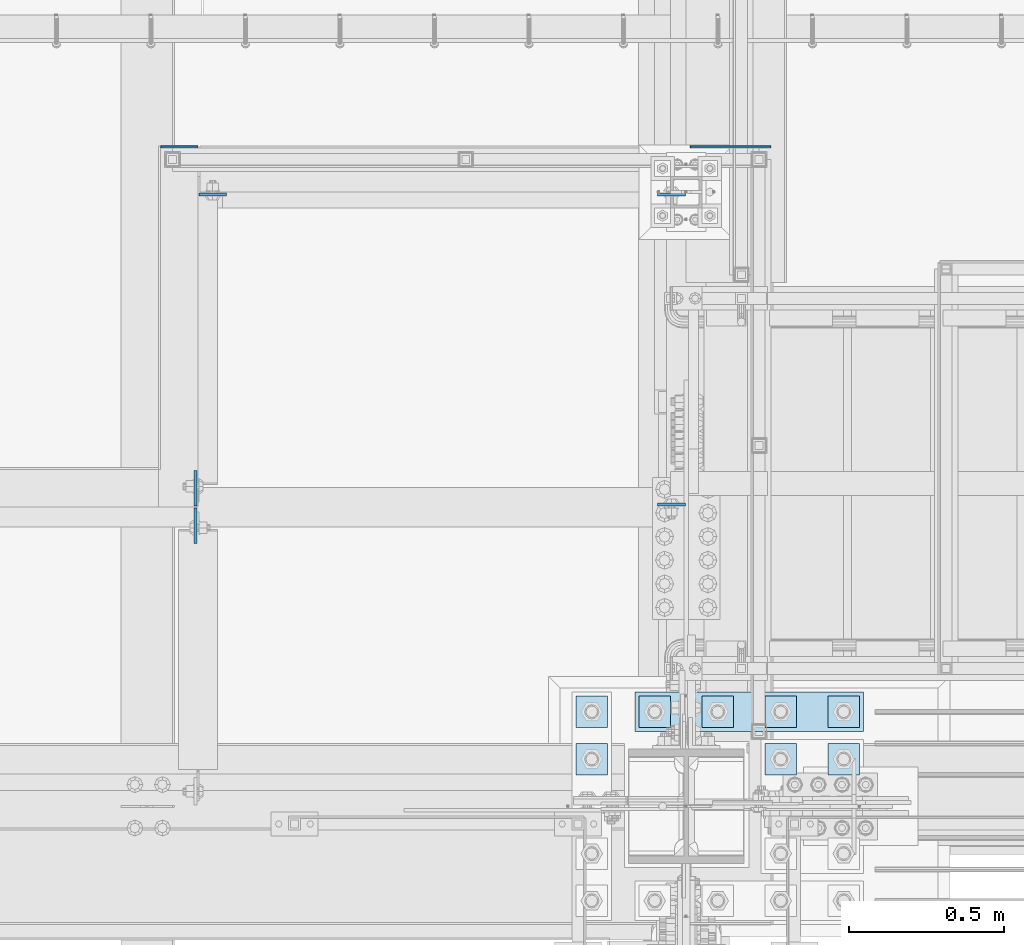
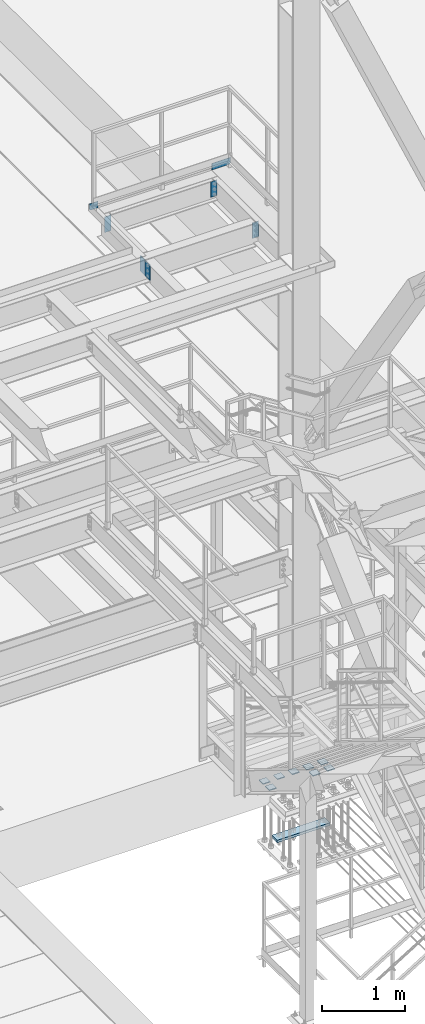
# One storey, part 3153 of 3843: 16 plates, 4 elements without a shape of their own.
"""IFC2X3 building model written with IfcOpenShell, lengths in millimetres."""

from ifc_helpers import new_model, si_unit, frame, origin_with_axes, place, context, subcontext, project, spatial, faceted_brep, material, type_object, element, aggregate, save


model = new_model("IFC2X3")

# Units and contexts
model_context = context("Model", 3, precision=1e-05, world=origin_with_axes())
body_context = subcontext(model_context, "Body", "Model", "MODEL_VIEW")
ifc_project = project(units=[si_unit("LENGTHUNIT", "METRE", prefix="MILLI"), si_unit("AREAUNIT", "SQUARE_METRE"), si_unit("VOLUMEUNIT", "CUBIC_METRE"), si_unit("MASSUNIT", "GRAM", prefix="KILO"), si_unit("TIMEUNIT", "SECOND"), si_unit("PLANEANGLEUNIT", "RADIAN"), si_unit("SOLIDANGLEUNIT", "STERADIAN"), si_unit("THERMODYNAMICTEMPERATUREUNIT", "DEGREE_CELSIUS"), si_unit("LUMINOUSINTENSITYUNIT", "LUMEN")], contexts=[model_context])

# Site, building, storey
site_placement = place(None, origin_with_axes())
site = spatial("IfcSite", under=ifc_project, at=site_placement, CompositionType="ELEMENT")
building_placement = place(site_placement, origin_with_axes())
building = spatial("IfcBuilding", under=site, at=building_placement, Name="Undefined", CompositionType="ELEMENT")
storey_placement = place(building_placement, origin_with_axes())
storey = spatial("IfcBuildingStorey", under=building, at=storey_placement, Name="Undefined", CompositionType="ELEMENT", Elevation=0.0)

# Assembly, plate
assembly_1_placement = place(storey_placement, origin_with_axes())
assembly_1 = element("IfcElementAssembly", 1, at=assembly_1_placement, inside=storey, Name="BEAM", AssemblyPlace="NOTDEFINED", PredefinedType="RIGID_FRAME")
ifc_material = material(Name="STEEL/A572-50")
plate_type_1 = type_object("IfcPlateType", PredefinedType="NOTDEFINED")
plate_1_placement = place(assembly_1_placement, frame((54359.175, 27589.1625, 37426.9), z_axis=(1.0, 0.0, 0.0), x_axis=(0.0, 0.0, -1.0)))
plate_1 = element("IfcPlate", 2, at=plate_1_placement, type_object=plate_type_1, material=ifc_material, Name="PLATE", context=body_context, shape_type="Brep", body=[
    faceted_brep([(0.0, -4.76249999999709, 0.0), (0.0, -4.76249999999709, 88.9000015258789), (0.0, 4.76249999999709, 88.9000015258789), (0.0, 4.76249999999709, 0.0), (228.600006102781, -4.7625000004191, 88.9000015257589), (228.600006102781, 4.76249999954598, 88.9000015257443), (228.600006103079, -4.7625000004482, 7.27595761418343e-12), (228.600006103079, 4.76249999954598, -7.27595761418343e-12)], [[[0, 1, 2, 3]], [[1, 4, 5, 2]], [[4, 6, 7, 5]], [[6, 0, 3, 7]], [[5, 7, 3, 2]], [[6, 4, 1, 0]]]),
])

# Assembly, plates
assembly_2_placement = place(storey_placement, origin_with_axes())
assembly_2 = element("IfcElementAssembly", 3, at=assembly_2_placement, inside=storey, Name="BEAM", AssemblyPlace="NOTDEFINED", PredefinedType="RIGID_FRAME")
plate_2_placement = place(assembly_2_placement, frame((55927.625, 27589.1625, 37426.9), z_axis=(-1.0, 0.0, 0.0), x_axis=(0.0, 0.0, -1.0)))
plate_2 = element("IfcPlate", 4, at=plate_2_placement, type_object=plate_type_1, material=ifc_material, Name="PLATE", context=body_context, shape_type="Brep", body=[
    faceted_brep([(0.0, -4.76249999999709, 0.0), (0.0, -4.76249999999709, 88.9000015258789), (0.0, 4.76249999999709, 88.9000015258789), (0.0, 4.76249999999709, 0.0), (228.600006102781, -4.7625000004191, 88.9000015257589), (228.600006102781, 4.76249999954598, 88.9000015257443), (228.600006103079, -4.7625000004482, 7.27595761418343e-12), (228.600006103079, 4.76249999954598, -7.27595761418343e-12)], [[[0, 1, 2, 3]], [[1, 4, 5, 2]], [[4, 6, 7, 5]], [[6, 0, 3, 7]], [[5, 7, 3, 2]], [[6, 4, 1, 0]]]),
])
plate_3_placement = place(assembly_2_placement, frame((55927.625, 26589.0375, 37426.9), z_axis=(-1.0, 0.0, 0.0), x_axis=(0.0, 0.0, -1.0)))
plate_3 = element("IfcPlate", 5, at=plate_3_placement, type_object=plate_type_1, material=ifc_material, Name="PLATE", context=body_context, shape_type="Brep", body=[
    faceted_brep([(0.0, -4.76249999999709, 0.0), (0.0, -4.76249999999709, 88.9000015258789), (0.0, 4.76249999999709, 88.9000015258789), (0.0, 4.76249999999709, 0.0), (228.600006102781, -4.7625000004191, 88.9000015257589), (228.600006102781, 4.76249999954598, 88.9000015257443), (228.600006103079, -4.7625000004482, 7.27595761418343e-12), (228.600006103079, 4.76249999954598, -7.27595761418343e-12)], [[[0, 1, 2, 3]], [[1, 4, 5, 2]], [[4, 6, 7, 5]], [[6, 0, 3, 7]], [[5, 7, 3, 2]], [[6, 4, 1, 0]]]),
])

# Plate
plate_type_2 = type_object("IfcPlateType", PredefinedType="NOTDEFINED")
plate_4_placement = place(assembly_1_placement, frame((54235.35, 27743.15, 37471.35), z_axis=(0.0, 0.0, 1.0), x_axis=(1.0, 0.0, 0.0)))
plate_4 = element("IfcPlate", 6, at=plate_4_placement, type_object=plate_type_2, material=ifc_material, Name="PLATE", context=body_context, shape_type="Brep", body=[
    faceted_brep([(4.36557456851006e-11, -3.17499999998836, 19.0499992370969), (0.0, -3.17499999999927, 95.25), (-2.44140610448085e-05, 3.17500000000291, 95.2499999999927), (1.45519152283669e-11, 3.17499999998836, 19.0499992370824), (120.649996948239, -3.17499999999927, 95.25), (120.649996948239, 3.17499999999927, 95.25), (120.650001525879, -3.17499999999927, 0.0), (120.650001525879, 3.17499999999927, 0.0), (19.0499992370023, -3.17500000005384, 0.0), (19.0499992369587, 3.17499999992287, -1.45519152283669e-11)], [[[0, 1, 2, 3]], [[1, 4, 5, 2]], [[4, 6, 7, 5]], [[6, 8, 9, 7]], [[8, 0, 3, 9]], [[5, 7, 9, 3, 2]], [[8, 6, 4, 1, 0]]]),
])

aggregate(assembly_1, [plate_4, plate_1])

plate_5_placement = place(assembly_2_placement, frame((55943.5, 27743.1497862042, 37471.35), z_axis=(0.0, 0.0, 1.0), x_axis=(1.0, 0.0, 0.0)))
plate_5 = element("IfcPlate", 7, at=plate_5_placement, type_object=plate_type_2, material=ifc_material, Name="PLATE", context=body_context, shape_type="Brep", body=[
    faceted_brep([(0.0, -3.17499999999927, 0.0), (0.0, -3.17499999999927, 95.25), (-2.44140610448085e-05, 3.17500000000291, 95.2499999999927), (0.0, 3.17499999999927, 0.0), (260.350006103516, -3.17499999999927, 95.25), (260.350006103516, 3.17499999999927, 95.25), (260.350006103516, -3.17499999999927, 19.0499992370605), (260.350006103516, 3.17499999999927, 19.0499992370605), (241.300006866455, -3.17499999999927, 0.0), (241.300006866455, 3.17499999999927, 0.0)], [[[0, 1, 2, 3]], [[1, 4, 5, 2]], [[4, 6, 7, 5]], [[6, 8, 9, 7]], [[8, 0, 3, 9]], [[5, 7, 9, 3, 2]], [[8, 6, 4, 1, 0]]]),
])

aggregate(assembly_2, [plate_5, plate_2, plate_3])

# Assembly, plates
assembly_3_placement = place(storey_placement, origin_with_axes())
assembly_3 = element("IfcElementAssembly", 8, at=assembly_3_placement, inside=storey, Name="BEAM", AssemblyPlace="NOTDEFINED", PredefinedType="RIGID_FRAME")
plate_type_3 = type_object("IfcPlateType", PredefinedType="NOTDEFINED")
plate_6_placement = place(assembly_3_placement, frame((54348.0625, 26584.275, 37404.675), z_axis=(0.0, 1.0, 0.0), x_axis=(0.0, 0.0, -1.0)))
plate_6 = element("IfcPlate", 9, at=plate_6_placement, type_object=plate_type_3, material=ifc_material, Name="PLATE", context=body_context, shape_type="Brep", body=[
    faceted_brep([(0.0, -4.76249999999709, 0.0), (0.0, -4.76249999999709, 114.300003051758), (0.0, 4.76249999999709, 114.300003051758), (0.0, 4.76249999999709, 0.0), (228.600006103516, -4.76249999999709, 114.300003051758), (228.600006103516, 4.76249999999709, 114.300003051758), (228.600006103079, -4.7625000004482, 7.27595761418343e-12), (228.600006103079, 4.76249999954598, -7.27595761418343e-12)], [[[0, 1, 2, 3]], [[1, 4, 5, 2]], [[4, 6, 7, 5]], [[6, 0, 3, 7]], [[5, 7, 3, 2]], [[6, 4, 1, 0]]]),
])
plate_7_placement = place(assembly_3_placement, frame((54348.0625, 26577.925, 37404.675), z_axis=(0.0, -1.0, 0.0), x_axis=(0.0, 0.0, -1.0)))
plate_7 = element("IfcPlate", 10, at=plate_7_placement, type_object=plate_type_3, material=ifc_material, Name="PLATE", context=body_context, shape_type="Brep", body=[
    faceted_brep([(0.0, -4.76249999999709, 0.0), (0.0, -4.76249999999709, 114.300003051758), (0.0, 4.76249999999709, 114.300003051758), (0.0, 4.76249999999709, 0.0), (228.600006103516, -4.76249999999709, 114.300003051758), (228.600006103516, 4.76249999999709, 114.300003051758), (228.600006103079, -4.7625000004482, 7.27595761418343e-12), (228.600006103079, 4.76249999954598, -7.27595761418343e-12)], [[[0, 1, 2, 3]], [[1, 4, 5, 2]], [[4, 6, 7, 5]], [[6, 0, 3, 7]], [[5, 7, 3, 2]], [[6, 4, 1, 0]]]),
])
aggregate(assembly_3, [plate_6, plate_7])

assembly_4_placement = place(storey_placement, origin_with_axes())
assembly_4 = element("IfcElementAssembly", 11, at=assembly_4_placement, inside=storey, Name="TEMPLATE", AssemblyPlace="NOTDEFINED", PredefinedType="RIGID_FRAME")
plate_type_4 = type_object("IfcPlateType", PredefinedType="NOTDEFINED")
plate_8_placement = place(assembly_4_placement, frame((55676.8, 25819.1, 29686.25), z_axis=(-1.0, 0.0, 0.0), x_axis=(0.0, -1.0, 0.0)))
plate_8 = element("IfcPlate", 12, at=plate_8_placement, type_object=plate_type_4, material=ifc_material, Name="Washer Plate", context=body_context, shape_type="Brep", body=[
    faceted_brep([(0.0, -6.3499999046162, 0.0), (-1.67347025126219e-10, -6.35000000000582, 101.600000000151), (-1.67347025126219e-10, 6.35000000000582, 101.600000000151), (7.27595761418343e-12, 6.3499999046162, 0.0), (101.599998474121, -6.34999999999854, 101.599998474121), (101.599998474121, 6.34999999999854, 101.599998474121), (101.6, -6.34999999999854, 0.0), (101.6, 6.34999999999854, 0.0)], [[[0, 1, 2, 3]], [[1, 4, 5, 2]], [[4, 6, 7, 5]], [[6, 0, 3, 7]], [[5, 7, 3, 2]], [[6, 4, 1, 0]]]),
])
plate_9_placement = place(assembly_4_placement, frame((56286.4, 25819.1, 29686.25), z_axis=(-1.0, 0.0, 0.0), x_axis=(0.0, -1.0, 0.0)))
plate_9 = element("IfcPlate", 13, at=plate_9_placement, type_object=plate_type_4, material=ifc_material, Name="Washer Plate", context=body_context, shape_type="Brep", body=[
    faceted_brep([(0.0, -6.3499999046162, 0.0), (-1.67347025126219e-10, -6.35000000000582, 101.600000000151), (-1.67347025126219e-10, 6.35000000000582, 101.600000000151), (7.27595761418343e-12, 6.3499999046162, 0.0), (101.599998474121, -6.34999999999854, 101.599998474121), (101.599998474121, 6.34999999999854, 101.599998474121), (101.6, -6.34999999999854, 0.0), (101.6, 6.34999999999854, 0.0)], [[[0, 1, 2, 3]], [[1, 4, 5, 2]], [[4, 6, 7, 5]], [[6, 0, 3, 7]], [[5, 7, 3, 2]], [[6, 4, 1, 0]]]),
])
plate_10_placement = place(assembly_4_placement, frame((56489.6, 25819.1, 29686.25), z_axis=(-1.0, 0.0, 0.0), x_axis=(0.0, -1.0, 0.0)))
plate_10 = element("IfcPlate", 14, at=plate_10_placement, type_object=plate_type_4, material=ifc_material, Name="Washer Plate", context=body_context, shape_type="Brep", body=[
    faceted_brep([(0.0, -6.3499999046162, 0.0), (-1.67347025126219e-10, -6.35000000000582, 101.600000000151), (-1.67347025126219e-10, 6.35000000000582, 101.600000000151), (7.27595761418343e-12, 6.3499999046162, 0.0), (101.599998474121, -6.34999999999854, 101.599998474121), (101.599998474121, 6.34999999999854, 101.599998474121), (101.6, -6.34999999999854, 0.0), (101.6, 6.34999999999854, 0.0)], [[[0, 1, 2, 3]], [[1, 4, 5, 2]], [[4, 6, 7, 5]], [[6, 0, 3, 7]], [[5, 7, 3, 2]], [[6, 4, 1, 0]]]),
])
plate_11_placement = place(assembly_4_placement, frame((55676.8, 25971.5, 29686.25), z_axis=(-1.0, 0.0, 0.0), x_axis=(0.0, -1.0, 0.0)))
plate_11 = element("IfcPlate", 15, at=plate_11_placement, type_object=plate_type_4, material=ifc_material, Name="Washer Plate", context=body_context, shape_type="Brep", body=[
    faceted_brep([(0.0, -6.3499999046162, 0.0), (-1.67347025126219e-10, -6.35000000000582, 101.600000000151), (-1.67347025126219e-10, 6.35000000000582, 101.600000000151), (7.27595761418343e-12, 6.3499999046162, 0.0), (101.599998474121, -6.34999999999854, 101.599998474121), (101.599998474121, 6.34999999999854, 101.599998474121), (101.6, -6.34999999999854, 0.0), (101.6, 6.34999999999854, 0.0)], [[[0, 1, 2, 3]], [[1, 4, 5, 2]], [[4, 6, 7, 5]], [[6, 0, 3, 7]], [[5, 7, 3, 2]], [[6, 4, 1, 0]]]),
])
plate_12_placement = place(assembly_4_placement, frame((55880.0, 25971.5, 29686.25), z_axis=(-1.0, 0.0, 0.0), x_axis=(0.0, -1.0, 0.0)))
plate_12 = element("IfcPlate", 16, at=plate_12_placement, type_object=plate_type_4, material=ifc_material, Name="Washer Plate", context=body_context, shape_type="Brep", body=[
    faceted_brep([(0.0, -6.3499999046162, 0.0), (-1.67347025126219e-10, -6.35000000000582, 101.600000000151), (-1.67347025126219e-10, 6.35000000000582, 101.600000000151), (7.27595761418343e-12, 6.3499999046162, 0.0), (101.599998474121, -6.34999999999854, 101.599998474121), (101.599998474121, 6.34999999999854, 101.599998474121), (101.6, -6.34999999999854, 0.0), (101.6, 6.34999999999854, 0.0)], [[[0, 1, 2, 3]], [[1, 4, 5, 2]], [[4, 6, 7, 5]], [[6, 0, 3, 7]], [[5, 7, 3, 2]], [[6, 4, 1, 0]]]),
])
plate_13_placement = place(assembly_4_placement, frame((56083.2, 25971.5, 29686.25), z_axis=(-1.0, 0.0, 0.0), x_axis=(0.0, -1.0, 0.0)))
plate_13 = element("IfcPlate", 17, at=plate_13_placement, type_object=plate_type_4, material=ifc_material, Name="Washer Plate", context=body_context, shape_type="Brep", body=[
    faceted_brep([(0.0, -6.3499999046162, 0.0), (-1.67347025126219e-10, -6.35000000000582, 101.600000000151), (-1.67347025126219e-10, 6.35000000000582, 101.600000000151), (7.27595761418343e-12, 6.3499999046162, 0.0), (101.599998474121, -6.34999999999854, 101.599998474121), (101.599998474121, 6.34999999999854, 101.599998474121), (101.6, -6.34999999999854, 0.0), (101.6, 6.34999999999854, 0.0)], [[[0, 1, 2, 3]], [[1, 4, 5, 2]], [[4, 6, 7, 5]], [[6, 0, 3, 7]], [[5, 7, 3, 2]], [[6, 4, 1, 0]]]),
])
plate_14_placement = place(assembly_4_placement, frame((56286.4, 25971.5, 29686.25), z_axis=(-1.0, 0.0, 0.0), x_axis=(0.0, -1.0, 0.0)))
plate_14 = element("IfcPlate", 18, at=plate_14_placement, type_object=plate_type_4, material=ifc_material, Name="Washer Plate", context=body_context, shape_type="Brep", body=[
    faceted_brep([(0.0, -6.3499999046162, 0.0), (-1.67347025126219e-10, -6.35000000000582, 101.600000000151), (-1.67347025126219e-10, 6.35000000000582, 101.600000000151), (7.27595761418343e-12, 6.3499999046162, 0.0), (101.599998474121, -6.34999999999854, 101.599998474121), (101.599998474121, 6.34999999999854, 101.599998474121), (101.6, -6.34999999999854, 0.0), (101.6, 6.34999999999854, 0.0)], [[[0, 1, 2, 3]], [[1, 4, 5, 2]], [[4, 6, 7, 5]], [[6, 0, 3, 7]], [[5, 7, 3, 2]], [[6, 4, 1, 0]]]),
])
plate_15_placement = place(assembly_4_placement, frame((56489.6, 25971.5, 29686.25), z_axis=(-1.0, 0.0, 0.0), x_axis=(0.0, -1.0, 0.0)))
plate_15 = element("IfcPlate", 19, at=plate_15_placement, type_object=plate_type_4, material=ifc_material, Name="Washer Plate", context=body_context, shape_type="Brep", body=[
    faceted_brep([(0.0, -6.3499999046162, 0.0), (-1.67347025126219e-10, -6.35000000000582, 101.600000000151), (-1.67347025126219e-10, 6.35000000000582, 101.600000000151), (7.27595761418343e-12, 6.3499999046162, 0.0), (101.599998474121, -6.34999999999854, 101.599998474121), (101.599998474121, 6.34999999999854, 101.599998474121), (101.6, -6.34999999999854, 0.0), (101.6, 6.34999999999854, 0.0)], [[[0, 1, 2, 3]], [[1, 4, 5, 2]], [[4, 6, 7, 5]], [[6, 0, 3, 7]], [[5, 7, 3, 2]], [[6, 4, 1, 0]]]),
])
plate_type_5 = type_object("IfcPlateType", PredefinedType="NOTDEFINED")
plate_16_placement = place(assembly_4_placement, frame((55765.7, 25984.2, 28784.55), z_axis=(1.0, 0.0, 0.0), x_axis=(0.0, -1.0, 0.0)))
plate_16 = element("IfcPlate", 20, at=plate_16_placement, type_object=plate_type_5, material=ifc_material, Name="PLATE", context=body_context, shape_type="Brep", body=[
    faceted_brep([(0.0, -19.0500000000029, 0.0), (0.0, -19.0499999999993, 736.600036621094), (0.0, 19.0499999999993, 736.600036621094), (0.0, 19.0500000000029, 0.0), (127.0, -19.0499999999993, 736.600036621094), (127.0, 19.0499999999993, 736.600036621094), (127.0, -19.0499999999993, 0.0), (127.0, 19.0499999999993, 0.0)], [[[0, 1, 2, 3]], [[1, 4, 5, 2]], [[4, 6, 7, 5]], [[6, 0, 3, 7]], [[5, 7, 3, 2]], [[6, 4, 1, 0]]]),
])
aggregate(assembly_4, [plate_8, plate_9, plate_10, plate_11, plate_12, plate_13, plate_14, plate_15, plate_16])

save(model, "model.ifc")
